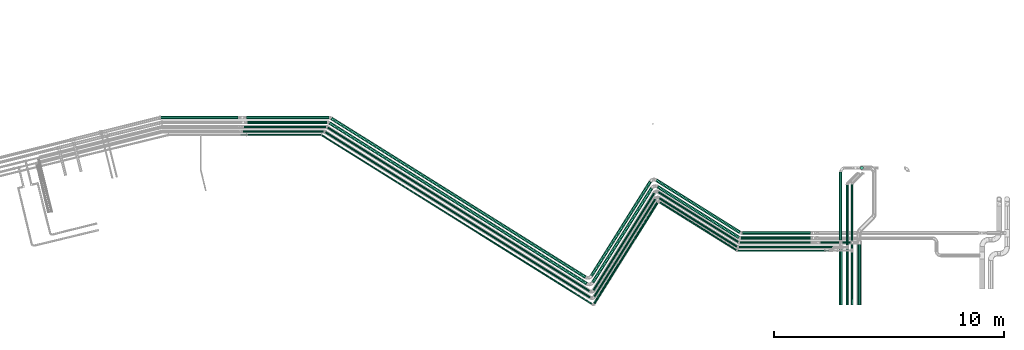
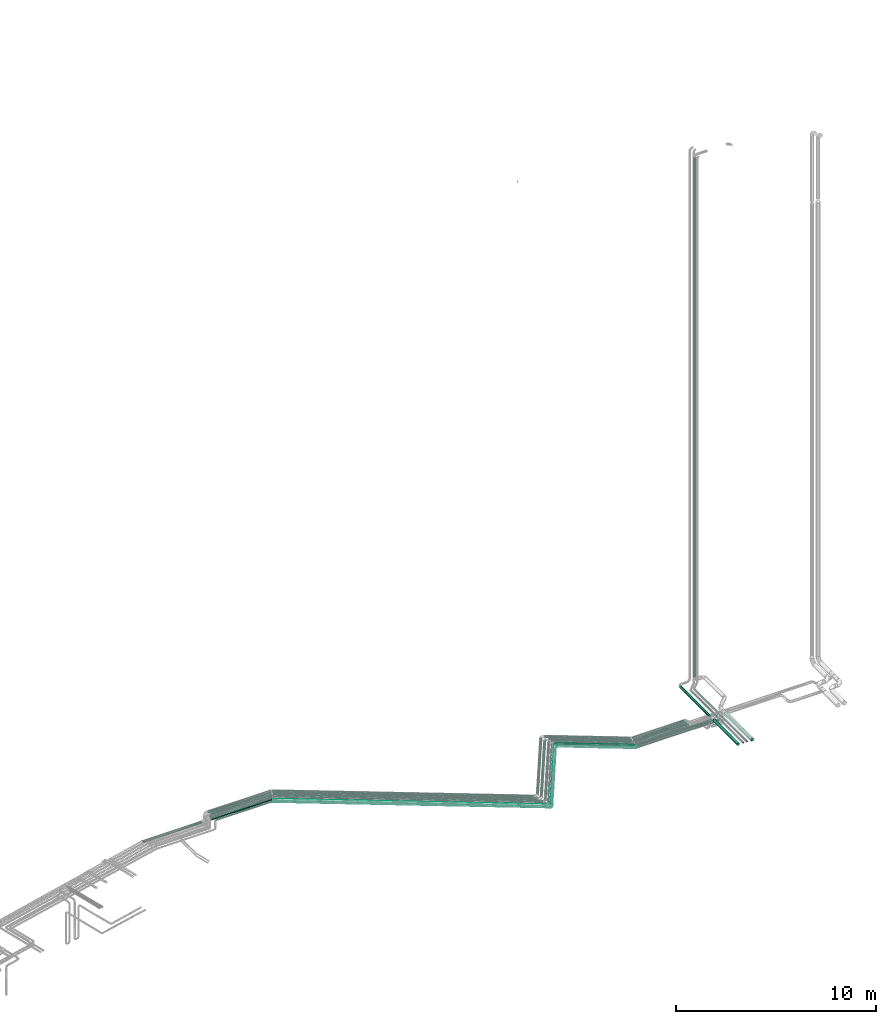
# One storey, part 43 of 93: 40 flow segments.
"""IFC2X3 building model written with IfcOpenShell, lengths in millimetres."""

from ifc_helpers import new_model, entity, si_unit, converted_unit, derived_unit, direction, frame, origin, origin_2d_with_axis, place, context, subcontext, project, spatial, circle, extrude, type_object, element, save


model = new_model("IFC2X3")

# Units and contexts
model_context = context("Model", 3, precision=0.01, world=origin(), true_north=direction((6.12303176911189e-17, 1.0)))
body_context = subcontext(model_context, "Body", "Model", "MODEL_VIEW")
ifc_project = project(units=[si_unit("LENGTHUNIT", "METRE", prefix="MILLI"), si_unit("AREAUNIT", "SQUARE_METRE"), si_unit("VOLUMEUNIT", "CUBIC_METRE"), converted_unit("PLANEANGLEUNIT", "DEGREE", entity("IfcRatioMeasure", 0.0174532925199433), si_unit("PLANEANGLEUNIT", "RADIAN"), dimensions=[0, 0, 0, 0, 0, 0, 0]), si_unit("MASSUNIT", "GRAM", prefix="KILO"), derived_unit("MASSDENSITYUNIT", [(si_unit("MASSUNIT", "GRAM", prefix="KILO"), 1), (si_unit("LENGTHUNIT", "METRE"), -3)]), derived_unit("MOMENTOFINERTIAUNIT", [(si_unit("LENGTHUNIT", "METRE"), 4)]), si_unit("TIMEUNIT", "SECOND"), si_unit("FREQUENCYUNIT", "HERTZ"), si_unit("THERMODYNAMICTEMPERATUREUNIT", "DEGREE_CELSIUS"), derived_unit("THERMALTRANSMITTANCEUNIT", [(si_unit("MASSUNIT", "GRAM", prefix="KILO"), 1), (si_unit("THERMODYNAMICTEMPERATUREUNIT", "KELVIN"), -1), (si_unit("TIMEUNIT", "SECOND"), -3)]), derived_unit("VOLUMETRICFLOWRATEUNIT", [(si_unit("LENGTHUNIT", "METRE"), 3), (si_unit("TIMEUNIT", "SECOND"), -1)]), derived_unit("MASSFLOWRATEUNIT", [(si_unit("MASSUNIT", "GRAM", prefix="KILO"), 1), (si_unit("TIMEUNIT", "SECOND"), -1)]), derived_unit("ROTATIONALFREQUENCYUNIT", [(si_unit("TIMEUNIT", "SECOND"), -1)]), si_unit("ELECTRICCURRENTUNIT", "AMPERE"), si_unit("ELECTRICVOLTAGEUNIT", "VOLT"), si_unit("POWERUNIT", "WATT"), si_unit("FORCEUNIT", "NEWTON", prefix="KILO"), si_unit("ILLUMINANCEUNIT", "LUX"), si_unit("LUMINOUSFLUXUNIT", "LUMEN"), si_unit("LUMINOUSINTENSITYUNIT", "CANDELA"), derived_unit("USERDEFINED", [(si_unit("MASSUNIT", "GRAM", prefix="KILO"), -1), (si_unit("LENGTHUNIT", "METRE"), -2), (si_unit("TIMEUNIT", "SECOND"), 3), (si_unit("LUMINOUSFLUXUNIT", "LUMEN"), 1)]), derived_unit("LINEARVELOCITYUNIT", [(si_unit("LENGTHUNIT", "METRE"), 1), (si_unit("TIMEUNIT", "SECOND"), -1)]), si_unit("PRESSUREUNIT", "PASCAL"), derived_unit("USERDEFINED", [(si_unit("LENGTHUNIT", "METRE"), -2), (si_unit("MASSUNIT", "GRAM", prefix="KILO"), 1), (si_unit("TIMEUNIT", "SECOND"), -2)]), derived_unit("LINEARFORCEUNIT", [(si_unit("MASSUNIT", "GRAM", prefix="KILO"), 1), (si_unit("LENGTHUNIT", "METRE"), 1), (si_unit("TIMEUNIT", "SECOND"), -2), (si_unit("LENGTHUNIT", "METRE"), -1)]), derived_unit("PLANARFORCEUNIT", [(si_unit("MASSUNIT", "GRAM", prefix="KILO"), 1), (si_unit("LENGTHUNIT", "METRE"), 1), (si_unit("TIMEUNIT", "SECOND"), -2), (si_unit("LENGTHUNIT", "METRE"), -2)])], contexts=[model_context])

# Site, building, storey
site_placement = place(None, origin())
site = spatial("IfcSite", under=ifc_project, at=site_placement, CompositionType="ELEMENT")
building_placement = place(site_placement, origin())
building = spatial("IfcBuilding", under=site, at=building_placement, CompositionType="ELEMENT")
storey_placement = place(building_placement, frame((0.0, 0.0, -4200.0)))
storey = spatial("IfcBuildingStorey", under=building, at=storey_placement, CompositionType="ELEMENT", Elevation=-4200.0)

# Flow segments
pipe_segment_type_1 = type_object("IfcPipeSegmentType", PredefinedType="NOTDEFINED")
flow_segment_1_placement = place(storey_placement, frame((-1662.18, 14231.91, 2931.9)))
element("IfcFlowSegment", 1, at=flow_segment_1_placement, inside=storey, type_object=pipe_segment_type_1, context=body_context, shape_type="SweptSolid", body=[
    extrude(circle(Radius=66.5, at=origin_2d_with_axis()), frame((0.0, 68.1, 68.1), z_axis=(1.0, 0.0, 0.0), x_axis=(0.0, 1.0, 0.0)), (0.0, 0.0, 1.0), 3470.00000000001),
])
flow_segment_2_placement = place(storey_placement, frame((-1701.76, 14431.91, 2931.9)))
element("IfcFlowSegment", 2, at=flow_segment_2_placement, inside=storey, type_object=pipe_segment_type_1, context=body_context, shape_type="SweptSolid", body=[
    extrude(circle(Radius=66.5, at=origin_2d_with_axis()), frame((0.0, 68.1, 68.1), z_axis=(1.0, 0.0, 0.0), x_axis=(0.0, 1.0, 0.0)), (0.0, 0.0, 1.0), 3590.0),
])
flow_segment_3_placement = place(storey_placement, frame((1871.66, 7208.86, 2931.9)))
element("IfcFlowSegment", 3, at=flow_segment_3_placement, inside=storey, type_object=pipe_segment_type_1, context=body_context, shape_type="SweptSolid", body=[
    extrude(circle(Radius=66.5, at=origin_2d_with_axis()), frame((36.83, 7062.27, 68.1), z_axis=(0.848048096156426, -0.529919264233205, 0.0), x_axis=(-0.529919264233205, -0.848048096156426, 0.0)), (0.0, 0.0, 1.0), 13217.6368280217),
])
flow_segment_4_placement = place(storey_placement, frame((13321.51, 7290.46, 2931.9)))
element("IfcFlowSegment", 4, at=flow_segment_4_placement, inside=storey, type_object=pipe_segment_type_1, context=body_context, shape_type="SweptSolid", body=[
    extrude(circle(Radius=66.5, at=origin_2d_with_axis()), frame((57.99, 36.83, 68.1), z_axis=(0.529919264233208, 0.848048096156424, 0.0), x_axis=(0.848048096156424, -0.529919264233208, 0.0)), (0.0, 0.0, 1.0), 4839.99999995205),
])
flow_segment_5_placement = place(storey_placement, frame((16169.29, 9225.62, 2931.9)))
element("IfcFlowSegment", 5, at=flow_segment_5_placement, inside=storey, type_object=pipe_segment_type_1, context=body_context, shape_type="SweptSolid", body=[
    extrude(circle(Radius=66.5, at=origin_2d_with_axis()), frame((3571.47, 57.99, 68.1), z_axis=(-0.848048096156425, 0.529919264233206, 0.0), x_axis=(-0.529919264233206, -0.848048096156425, 0.0)), (0.0, 0.0, 1.0), 4167.96244380158),
])
flow_segment_6_placement = place(storey_placement, frame((1952.09, 7494.82, 2931.9)))
element("IfcFlowSegment", 6, at=flow_segment_6_placement, inside=storey, type_object=pipe_segment_type_1, context=body_context, shape_type="SweptSolid", body=[
    extrude(circle(Radius=66.5, at=origin_2d_with_axis()), frame((11108.46, 57.99, 68.1), z_axis=(-0.848048096156424, 0.529919264233209, 0.0), x_axis=(-0.529919264233209, -0.848048096156424, 0.0)), (0.0, 0.0, 1.0), 13055.4167034884),
])
flow_segment_7_placement = place(storey_placement, frame((13264.37, 7576.42, 2931.9)))
element("IfcFlowSegment", 7, at=flow_segment_7_placement, inside=storey, type_object=pipe_segment_type_1, context=body_context, shape_type="SweptSolid", body=[
    extrude(circle(Radius=66.5, at=origin_2d_with_axis()), frame((57.99, 36.83, 68.1), z_axis=(0.52991926423321, 0.848048096156423, 0.0), x_axis=(0.848048096156423, -0.52991926423321, 0.0)), (0.0, 0.0, 1.0), 4839.99999992639),
])
flow_segment_8_placement = place(storey_placement, frame((16112.15, 9445.02, 2931.9)))
element("IfcFlowSegment", 8, at=flow_segment_8_placement, inside=storey, type_object=pipe_segment_type_1, context=body_context, shape_type="SweptSolid", body=[
    extrude(circle(Radius=66.5, at=origin_2d_with_axis()), frame((3677.99, 57.99, 68.1), z_axis=(-0.848048096156423, 0.529919264233209, 0.0), x_axis=(-0.529919264233209, -0.848048096156423, 0.0)), (0.0, 0.0, 1.0), 4293.57017112024),
])
flow_segment_9_placement = place(storey_placement, frame((19890.82, 9406.04, 2931.9)))
element("IfcFlowSegment", 9, at=flow_segment_9_placement, inside=storey, type_object=pipe_segment_type_1, context=body_context, shape_type="SweptSolid", body=[
    extrude(circle(Radius=66.5, at=origin_2d_with_axis()), frame((0.0, 68.1, 68.1), z_axis=(1.0, 0.0, 0.0), x_axis=(0.0, -1.0, 0.0)), (0.0, 0.0, 1.0), 2962.34690637158),
])
flow_segment_10_placement = place(storey_placement, frame((19841.45, 9186.64, 2931.9)))
element("IfcFlowSegment", 10, at=flow_segment_10_placement, inside=storey, type_object=pipe_segment_type_1, context=body_context, shape_type="SweptSolid", body=[
    extrude(circle(Radius=66.5, at=origin_2d_with_axis()), frame((0.0, 68.1, 68.1), z_axis=(1.0, 0.0, 0.0), x_axis=(0.0, -1.0, 0.0)), (0.0, 0.0, 1.0), 3011.72234269005),
])
flow_segment_11_placement = place(storey_placement, frame((24111.2, 9168.64, 2932.66)))
element("IfcFlowSegment", 11, at=flow_segment_11_placement, inside=storey, type_object=pipe_segment_type_1, context=body_context, shape_type="SweptSolid", body=[
    extrude(circle(Radius=66.5, at=origin_2d_with_axis()), frame((68.1, 0.0, 68.1), z_axis=(0.0, 1.0, 0.0), x_axis=(1.0, 0.0, 0.0)), (0.0, 0.0, 1.0), 2956.92721857099),
])
flow_segment_12_placement = place(storey_placement, frame((24098.2, 6345.74, 2919.66)))
element("IfcFlowSegment", 12, at=flow_segment_12_placement, inside=storey, type_object=pipe_segment_type_1, context=body_context, shape_type="SweptSolid", body=[
    extrude(circle(Radius=79.5, at=origin_2d_with_axis()), frame((81.1, 0.0, 81.1), z_axis=(0.0, 1.0, 0.0), x_axis=(-1.0, 0.0, 0.0)), (0.0, 0.0, 1.0), 2436.74162061539),
])
flow_segment_13_placement = place(storey_placement, frame((16244.8, 8838.88, 2954.66)))
element("IfcFlowSegment", 13, at=flow_segment_13_placement, inside=storey, type_object=pipe_segment_type_1, context=body_context, shape_type="SweptSolid", body=[
    extrude(circle(Radius=44.5, at=origin_2d_with_axis()), frame((3423.96, 39.33, 46.1), z_axis=(-0.848048096872166, 0.529919263087781, 0.0), x_axis=(0.529919263087781, 0.848048096872166, 0.0)), (0.0, 0.0, 1.0), 4007.77716045076),
])
flow_segment_14_placement = place(storey_placement, frame((13399.79, 6672.98, 2954.66)))
element("IfcFlowSegment", 14, at=flow_segment_14_placement, inside=storey, type_object=pipe_segment_type_1, context=body_context, shape_type="SweptSolid", body=[
    extrude(circle(Radius=44.5, at=origin_2d_with_axis()), frame((39.33, 25.18, 46.1), z_axis=(0.529919264233208, 0.848048096156424, 0.0), x_axis=(-0.848048096156424, 0.529919264233208, 0.0)), (0.0, 0.0, 1.0), 5029.99999999998),
])
flow_segment_15_placement = place(storey_placement, frame((1691.32, 6620.65, 2953.9)))
element("IfcFlowSegment", 15, at=flow_segment_15_placement, inside=storey, type_object=pipe_segment_type_1, context=body_context, shape_type="SweptSolid", body=[
    extrude(circle(Radius=44.5, at=origin_2d_with_axis()), frame((11582.45, 39.33, 46.85), z_axis=(-0.848048094870503, 0.529919263429674, -5.5069602747006e-05), x_axis=(-0.529919264233207, -0.848048096156425, 0.0)), (0.0, 0.0, 1.0), 13628.0909050597),
])
flow_segment_16_placement = place(storey_placement, frame((19790.5, 9015.05, 2950.91)))
element("IfcFlowSegment", 16, at=flow_segment_16_placement, inside=storey, type_object=pipe_segment_type_1, context=body_context, shape_type="SweptSolid", body=[
    extrude(circle(Radius=44.5, at=origin_2d_with_axis()), frame((0.0, 46.1, 46.1), z_axis=(1.0, 0.0, 0.0), x_axis=(0.0, -1.0, 0.0)), (0.0, 0.0, 1.0), 3082.63986313707),
])
flow_segment_17_placement = place(storey_placement, frame((16203.03, 9040.04, 2950.91)))
element("IfcFlowSegment", 17, at=flow_segment_17_placement, inside=storey, type_object=pipe_segment_type_1, context=body_context, shape_type="SweptSolid", body=[
    extrude(circle(Radius=44.5, at=origin_2d_with_axis()), frame((3523.88, 39.33, 46.1), z_axis=(-0.848048096872165, 0.529919263087784, 0.0), x_axis=(0.529919263087784, 0.848048096872165, 0.0)), (0.0, 0.0, 1.0), 4125.59056056346),
])
flow_segment_18_placement = place(storey_placement, frame((13368.62, 6953.53, 2950.91)))
element("IfcFlowSegment", 18, at=flow_segment_18_placement, inside=storey, type_object=pipe_segment_type_1, context=body_context, shape_type="SweptSolid", body=[
    extrude(circle(Radius=44.5, at=origin_2d_with_axis()), frame((39.33, 25.18, 46.1), z_axis=(0.529919264233209, 0.848048096156423, 0.0), x_axis=(-0.848048096156423, 0.529919264233209, 0.0)), (0.0, 0.0, 1.0), 5010.0017049427),
])
flow_segment_19_placement = place(storey_placement, frame((1795.22, 6901.2, 2950.91)))
element("IfcFlowSegment", 19, at=flow_segment_19_placement, inside=storey, type_object=pipe_segment_type_1, context=body_context, shape_type="SweptSolid", body=[
    extrude(circle(Radius=44.5, at=origin_2d_with_axis()), frame((11447.39, 39.33, 46.1), z_axis=(-0.848048096156425, 0.529919264233207, 0.0), x_axis=(0.529919264233207, 0.848048096156425, 0.0)), (0.0, 0.0, 1.0), 13468.8235901615),
])
flow_segment_20_placement = place(storey_placement, frame((24898.2, 6345.74, 2918.9)))
element("IfcFlowSegment", 20, at=flow_segment_20_placement, inside=storey, type_object=pipe_segment_type_1, context=body_context, shape_type="SweptSolid", body=[
    extrude(circle(Radius=79.5, at=origin_2d_with_axis()), frame((81.1, 0.0, 81.1), z_axis=(0.0, 1.0, 0.0), x_axis=(1.0, 0.0, 0.0)), (0.0, 0.0, 1.0), 2637.900342002),
])
flow_segment_21_placement = place(storey_placement, frame((24634.86, 8787.14, 2960.4)))
element("IfcFlowSegment", 21, at=flow_segment_21_placement, inside=storey, type_object=pipe_segment_type_1, context=body_context, shape_type="SweptSolid", body=[
    extrude(circle(Radius=38.0, at=origin_2d_with_axis()), frame((39.6, 0.0, 39.6), z_axis=(0.0, 1.0, 0.0), x_axis=(1.0, 0.0, 0.0)), (0.0, 0.0, 1.0), 2807.17830176069),
])
flow_segment_22_placement = place(storey_placement, frame((24428.45, 8937.14, 2960.4)))
element("IfcFlowSegment", 22, at=flow_segment_22_placement, inside=storey, type_object=pipe_segment_type_1, context=body_context, shape_type="SweptSolid", body=[
    extrude(circle(Radius=38.0, at=origin_2d_with_axis()), frame((39.6, 0.0, 39.6), z_axis=(0.0, 1.0, 0.0), x_axis=(1.0, 0.0, 0.0)), (0.0, 0.0, 1.0), 2647.17830176069),
])
flow_segment_23_placement = place(storey_placement, frame((24428.45, 6345.74, 2960.4)))
element("IfcFlowSegment", 23, at=flow_segment_23_placement, inside=storey, type_object=pipe_segment_type_1, context=body_context, shape_type="SweptSolid", body=[
    extrude(circle(Radius=38.0, at=origin_2d_with_axis()), frame((39.6, 0.0, 39.6), z_axis=(0.0, 1.0, 0.0), x_axis=(1.0, 0.0, 0.0)), (0.0, 0.0, 1.0), 2439.40034200199),
])
flow_segment_24_placement = place(storey_placement, frame((24634.86, 6345.74, 2960.4)))
element("IfcFlowSegment", 24, at=flow_segment_24_placement, inside=storey, type_object=pipe_segment_type_1, context=body_context, shape_type="SweptSolid", body=[
    extrude(circle(Radius=38.0, at=origin_2d_with_axis()), frame((39.6, 0.0, 39.6), z_axis=(0.0, 1.0, 0.0), x_axis=(1.0, 0.0, 0.0)), (0.0, 0.0, 1.0), 2289.40034200199),
])
flow_segment_25_placement = place(storey_placement, frame((19732.35, 8813.89, 2954.66)))
element("IfcFlowSegment", 25, at=flow_segment_25_placement, inside=storey, type_object=pipe_segment_type_1, context=body_context, shape_type="SweptSolid", body=[
    extrude(circle(Radius=44.5, at=origin_2d_with_axis()), frame((0.0, 46.1, 46.1), z_axis=(1.0, 0.0, 0.0), x_axis=(0.0, 1.0, 0.0)), (0.0, 0.0, 1.0), 4364.44138685684),
])
flow_segment_26_placement = place(storey_placement, frame((-5452.68, 14431.91, 2431.9)))
element("IfcFlowSegment", 26, at=flow_segment_26_placement, inside=storey, type_object=pipe_segment_type_1, context=body_context, shape_type="SweptSolid", body=[
    extrude(circle(Radius=66.5, at=origin_2d_with_axis()), frame((0.0, 68.1, 68.1), z_axis=(1.0, 0.0, 0.0), x_axis=(0.0, -1.0, 0.0)), (0.0, 0.0, 1.0), 3370.91944682417),
])
flow_segment_27_placement = place(storey_placement, frame((-1833.3, 14050.06, 2950.94)))
element("IfcFlowSegment", 27, at=flow_segment_27_placement, inside=storey, type_object=pipe_segment_type_1, context=body_context, shape_type="SweptSolid", body=[
    extrude(circle(Radius=44.5, at=origin_2d_with_axis()), frame((0.06, 49.96, 49.5), z_axis=(0.99999896917087, -0.00107763060458495, -0.000948878009774171), x_axis=(0.00107763108971813, 0.999999419355449, 0.0)), (0.0, 0.0, 1.0), 3590.17075329838),
])
flow_segment_28_placement = place(storey_placement, frame((-1871.09, 13853.91, 2953.9)))
element("IfcFlowSegment", 28, at=flow_segment_28_placement, inside=storey, type_object=pipe_segment_type_1, context=body_context, shape_type="SweptSolid", body=[
    extrude(circle(Radius=44.5, at=origin_2d_with_axis()), frame((0.0, 46.1, 46.1), z_axis=(1.0, 0.0, 0.0), x_axis=(0.0, 1.0, 0.0)), (0.0, 0.0, 1.0), 3523.99516441845),
])
flow_segment_29_placement = place(storey_placement, frame((23281.68, 9015.05, 2641.77)))
element("IfcFlowSegment", 29, at=flow_segment_29_placement, inside=storey, type_object=pipe_segment_type_1, context=body_context, shape_type="SweptSolid", body=[
    extrude(circle(Radius=44.5, at=origin_2d_with_axis()), frame((0.0, 46.1, 46.1), z_axis=(1.0, 0.0, 0.0), x_axis=(0.0, 1.0, 0.0)), (0.0, 0.0, 1.0), 1332.01994670235),
])
pipe_segment_type_2 = type_object("IfcPipeSegmentType", PredefinedType="NOTDEFINED")
flow_segment_30_placement = place(storey_placement, frame((25027.53, 12243.97, 3190.0)))
element("IfcFlowSegment", 30, at=flow_segment_30_placement, inside=storey, type_object=pipe_segment_type_2, context=body_context, shape_type="SweptSolid", body=[
    extrude(circle(Radius=70.0, at=origin_2d_with_axis()), frame((71.6, 71.6, 0.0), z_axis=(0.0, 0.0, 1.0), x_axis=(-1.0, 0.0, 0.0)), (0.0, 0.0, 1.0), 31620.0),
])
flow_segment_31_placement = place(storey_placement, frame((19661.55, 8685.55, 2917.25)))
element("IfcFlowSegment", 31, at=flow_segment_31_placement, inside=storey, type_object=pipe_segment_type_2, context=body_context, shape_type="SweptSolid", body=[
    extrude(circle(Radius=24.0, at=origin_2d_with_axis()), frame((0.0, 25.6, 25.6), z_axis=(1.0, 0.0, 0.0), x_axis=(0.0, 1.0, 0.0)), (0.0, 0.0, 1.0), 3805.04533999816),
])
flow_segment_32_placement = place(storey_placement, frame((19692.0, 8685.55, 3033.21)))
element("IfcFlowSegment", 32, at=flow_segment_32_placement, inside=storey, type_object=pipe_segment_type_2, context=body_context, shape_type="SweptSolid", body=[
    extrude(circle(Radius=24.0, at=origin_2d_with_axis()), frame((0.0, 25.6, 25.6), z_axis=(1.0, 0.0, 0.0), x_axis=(0.0, 1.0, 0.0)), (0.0, 0.0, 1.0), 3960.04533999814),
])
flow_segment_33_placement = place(storey_placement, frame((16270.08, 8697.85, 2917.25)))
element("IfcFlowSegment", 33, at=flow_segment_33_placement, inside=storey, type_object=pipe_segment_type_2, context=body_context, shape_type="SweptSolid", body=[
    extrude(circle(Radius=24.0, at=origin_2d_with_axis()), frame((3361.27, 21.95, 25.6), z_axis=(-0.848048096872167, 0.529919263087781, 0.0), x_axis=(0.529919263087781, 0.848048096872167, 0.0)), (0.0, 0.0, 1.0), 3946.65551305345),
])
flow_segment_34_placement = place(storey_placement, frame((13428.39, 6369.03, 2917.25)))
element("IfcFlowSegment", 34, at=flow_segment_34_placement, inside=storey, type_object=pipe_segment_type_2, context=body_context, shape_type="SweptSolid", body=[
    extrude(circle(Radius=24.0, at=origin_2d_with_axis()), frame((21.95, 14.31, 25.6), z_axis=(0.529919264233211, 0.848048096156422, 0.0), x_axis=(-0.848048096156422, 0.529919264233211, 0.0)), (0.0, 0.0, 1.0), 5199.86161627023),
])
flow_segment_35_placement = place(storey_placement, frame((1553.21, 6343.26, 2917.25)))
element("IfcFlowSegment", 35, at=flow_segment_35_placement, inside=storey, type_object=pipe_segment_type_2, context=body_context, shape_type="SweptSolid", body=[
    extrude(circle(Radius=24.0, at=origin_2d_with_axis()), frame((14.31, 7398.08, 25.6), z_axis=(0.848048096156422, -0.529919264233212, 0.0), x_axis=(-0.529919264233212, -0.848048096156422, 0.0)), (0.0, 0.0, 1.0), 13919.3436019751),
])
flow_segment_36_placement = place(storey_placement, frame((16249.65, 8697.85, 3033.21)))
element("IfcFlowSegment", 36, at=flow_segment_36_placement, inside=storey, type_object=pipe_segment_type_2, context=body_context, shape_type="SweptSolid", body=[
    extrude(circle(Radius=24.0, at=origin_2d_with_axis()), frame((14.31, 2145.15, 25.6), z_axis=(0.848048096872167, -0.529919263087781, 0.0), x_axis=(0.529919263087781, 0.848048096872167, 0.0)), (0.0, 0.0, 1.0), 4006.65551305341),
])
flow_segment_37_placement = place(storey_placement, frame((13399.41, 6387.14, 3033.21)))
element("IfcFlowSegment", 37, at=flow_segment_37_placement, inside=storey, type_object=pipe_segment_type_2, context=body_context, shape_type="SweptSolid", body=[
    extrude(circle(Radius=24.0, at=origin_2d_with_axis()), frame((21.95, 14.31, 25.6), z_axis=(0.52991926423321, 0.848048096156423, 0.0), x_axis=(-0.848048096156423, 0.52991926423321, 0.0)), (0.0, 0.0, 1.0), 5215.99892406455),
])
flow_segment_38_placement = place(storey_placement, frame((1553.7, 6361.37, 3033.21)))
element("IfcFlowSegment", 38, at=flow_segment_38_placement, inside=storey, type_object=pipe_segment_type_2, context=body_context, shape_type="SweptSolid", body=[
    extrude(circle(Radius=24.0, at=origin_2d_with_axis()), frame((14.31, 7379.97, 25.6), z_axis=(0.848038093311225, -0.529935271795586, 0.0), x_axis=(0.529935271795586, 0.848038093311225, 0.0)), (0.0, 0.0, 1.0), 13884.7471169057),
])
flow_segment_39_placement = place(storey_placement, frame((-1948.84, 13724.41, 3033.21)))
element("IfcFlowSegment", 39, at=flow_segment_39_placement, inside=storey, type_object=pipe_segment_type_2, context=body_context, shape_type="SweptSolid", body=[
    extrude(circle(Radius=24.0, at=origin_2d_with_axis()), frame((0.0, 25.6, 25.6), z_axis=(1.0, 0.0, 0.0), x_axis=(0.0, -1.0, 0.0)), (0.0, 0.0, 1.0), 3486.65493081465),
])
flow_segment_40_placement = place(storey_placement, frame((-1648.84, 13724.41, 2917.25)))
element("IfcFlowSegment", 40, at=flow_segment_40_placement, inside=storey, type_object=pipe_segment_type_2, context=body_context, shape_type="SweptSolid", body=[
    extrude(circle(Radius=24.0, at=origin_2d_with_axis()), frame((0.0, 25.6, 25.6), z_axis=(1.0, 0.0, 0.0), x_axis=(0.0, 1.0, 0.0)), (0.0, 0.0, 1.0), 3186.15832154256),
])

save(model, "model.ifc")
